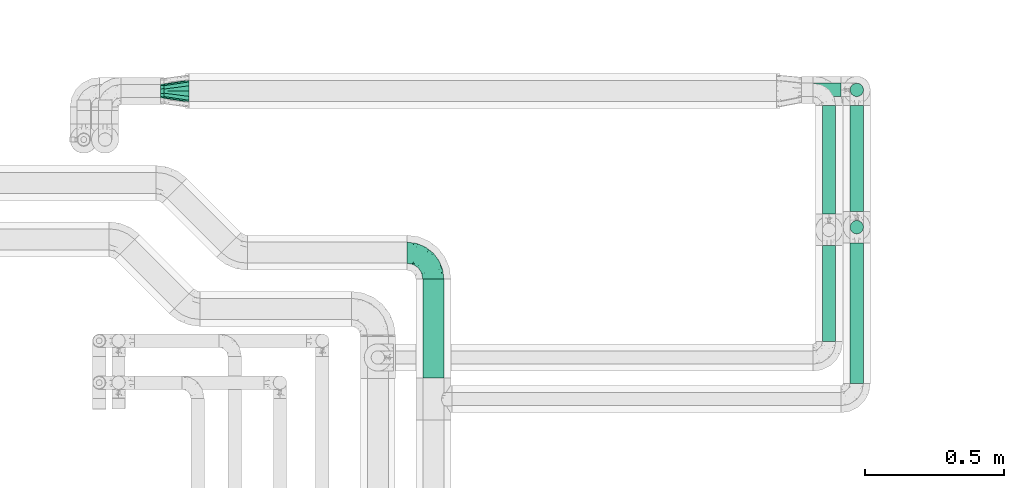
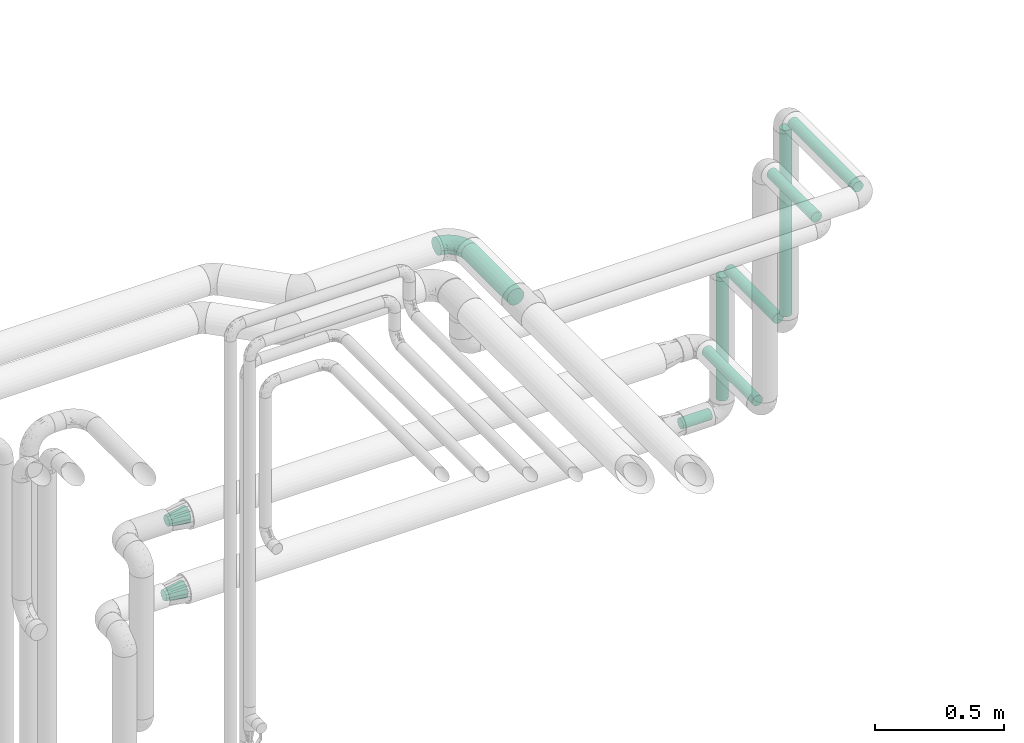
# One storey, part 684 of 824: 8 flow segments, 3 flow fittings.
"""IFC2X3 building model written with IfcOpenShell, lengths in millimetres."""

import ifcopenshell
import ifcopenshell.guid

model = None  # the IFC model being written
_history = None  # IfcOwnerHistory: only IFC2X3 demands one
_inside = {}  # id of a spatial element -> (the spatial element, [elements in it])
_under = {}  # id of a project, library or spatial element -> (it, [spatial elements below it])
_declared = {}  # id of a project -> (the project, [libraries it declares])
_typed = {}  # id of a type object -> (the type object, [elements of that type])
_made_of = {}  # id of a material, layer set ... -> (it, [elements and type objects made of it])


def new_model(schema):
    """Start an empty IFC model of exactly this schema.

    Asked for "IFC4X3", IfcOpenShell would pick the latest addendum, in which some entities
    have other attributes; the version numbers below select the first issue.
    IFC2X3 requires an IfcOwnerHistory on every rooted entity: one is made here for all.
    """
    global model, _history
    if schema == "IFC4X3":
        model = ifcopenshell.file(schema_version=(4, 3, 0, 0))
    else:
        model = ifcopenshell.file(schema=schema)
    _inside.clear()
    _under.clear()
    _declared.clear()
    _typed.clear()
    _made_of.clear()
    _history = None
    if model.schema == "IFC2X3":
        org = make("IfcOrganization", Name="unknown")
        user = make(
            "IfcPersonAndOrganization",
            ThePerson=make("IfcPerson", FamilyName="unknown"),
            TheOrganization=org,
        )
        app = make(
            "IfcApplication",
            ApplicationDeveloper=org,
            Version="unknown",
            ApplicationFullName="unknown",
            ApplicationIdentifier="unknown",
        )
        _history = make(
            "IfcOwnerHistory",
            OwningUser=user,
            OwningApplication=app,
            ChangeAction="ADDED",
            CreationDate=0,
        )
    return model


def make(cls, **values):
    """One entity of the class cls with the attributes given. An attribute that is None is left unset."""
    return model.create_entity(
        cls, **{name: value for name, value in values.items() if value is not None}
    )


def entity(cls, *values):
    """Any entity or typed value of the class cls, its attributes in the order of the schema. None: left unset."""
    e = model.create_entity(cls)
    for i, value in enumerate(values):
        if value is not None:
            e[i] = value
    return e


def rooted(cls, **values):
    """An entity with a GlobalId (a new one), such as an element, a storey or a relation."""
    return make(cls, GlobalId=ifcopenshell.guid.new(), OwnerHistory=_history, **values)


def si_unit(unit_type, name, prefix=None):
    """IfcSIUnit, for example si_unit("LENGTHUNIT", "METRE", prefix="MILLI")."""
    return make("IfcSIUnit", UnitType=unit_type, Prefix=prefix, Name=name)


def converted_unit(unit_type, name, factor, base, dimensions=None, offset=None):
    """IfcConversionBasedUnit, such as the inch: factor (a typed value) times the base unit."""
    return make(
        "IfcConversionBasedUnit"
        if offset is None
        else "IfcConversionBasedUnitWithOffset",
        ConversionOffset=offset,
        Dimensions=None
        if dimensions is None
        else entity("IfcDimensionalExponents", *dimensions),
        UnitType=unit_type,
        Name=name,
        ConversionFactor=make(
            "IfcMeasureWithUnit", ValueComponent=factor, UnitComponent=base
        ),
    )


def derived_unit(unit_type, elements):
    """IfcDerivedUnit: a product of units, each with its exponent."""
    return make(
        "IfcDerivedUnit",
        Elements=[
            make("IfcDerivedUnitElement", Unit=unit, Exponent=power)
            for unit, power in elements
        ],
        UnitType=unit_type,
    )


def assignment(units):
    """IfcUnitAssignment: the units of a project."""
    return None if units is None else make("IfcUnitAssignment", Units=units)


def point(xyz):
    """IfcCartesianPoint."""
    return None if xyz is None else make("IfcCartesianPoint", Coordinates=xyz)


def direction(xyz):
    """IfcDirection."""
    return None if xyz is None else make("IfcDirection", DirectionRatios=xyz)


def frame(location, z_axis=None, x_axis=None):
    """IfcAxis2Placement3D, a coordinate frame: its origin and axes. An axis left out is left unset."""
    return make(
        "IfcAxis2Placement3D",
        Location=point(location),
        Axis=direction(z_axis),
        RefDirection=direction(x_axis),
    )


def frame_2d(location, x_axis=None):
    """IfcAxis2Placement2D, a coordinate frame in the plane: its origin and x axis."""
    return make(
        "IfcAxis2Placement2D", Location=point(location), RefDirection=direction(x_axis)
    )


def origin():
    """The frame at (0, 0, 0) with its axes left unset."""
    return frame((0.0, 0.0, 0.0))


def origin_2d_with_axis():
    """The frame at (0, 0) in the plane with the x axis (1, 0) written out."""
    return frame_2d((0.0, 0.0), x_axis=(1.0, 0.0))


def place(relative_to, where):
    """IfcLocalPlacement: puts the frame where relative to a parent placement (None: the world)."""
    return make(
        "IfcLocalPlacement", PlacementRelTo=relative_to, RelativePlacement=where
    )


def context(
    kind, dimensions, precision=None, world=None, true_north=None, identifier=None
):
    """IfcGeometricRepresentationContext, for example the 3D "Model" context."""
    return make(
        "IfcGeometricRepresentationContext",
        ContextIdentifier=identifier,
        ContextType=kind,
        CoordinateSpaceDimension=dimensions,
        Precision=precision,
        WorldCoordinateSystem=world,
        TrueNorth=true_north,
    )


def subcontext(parent, identifier, kind, view, scale=None):
    """IfcGeometricRepresentationSubContext, for example "Body" below "Model"."""
    return make(
        "IfcGeometricRepresentationSubContext",
        ContextIdentifier=identifier,
        ContextType=kind,
        ParentContext=parent,
        TargetScale=scale,
        TargetView=view,
    )


def project(units=None, contexts=None):
    """IfcProject with its units and contexts."""
    return rooted(
        "IfcProject",
        Name="project",
        RepresentationContexts=contexts,
        UnitsInContext=assignment(units),
    )


def spatial(cls, under=None, at=None, **own):
    """A site, building, storey or space (cls), placed at a placement, below another one or the project."""
    s = rooted(cls, ObjectPlacement=at, **own)
    if under is not None:
        _under.setdefault(under.id(), (under, []))[1].append(s)
    return s


def profile(cls, at=None, kind="AREA", **sizes):
    """A parametric profile (cls). Its sizes go by their IFC names, for example OverallWidth=200.0."""
    return make(cls, ProfileType=kind, Position=at, **sizes)


def circle(**sizes):
    """IfcCircleProfileDef."""
    return profile("IfcCircleProfileDef", **sizes)


def extrude(swept, where, along, depth):
    """IfcExtrudedAreaSolid: the profile swept, set in the frame where, extruded along a direction by depth."""
    return make(
        "IfcExtrudedAreaSolid",
        SweptArea=swept,
        Position=where,
        ExtrudedDirection=direction(along),
        Depth=depth,
    )


def faces_of(points, faces, orient=None, outer=None):
    """IfcFace entities. A face is a list of loops; a loop is a list of indices into points, from 0.

    orient and outer hold one flag for each loop. By default every Orientation is true, the
    first loop of a face is its IfcFaceOuterBound and the others are IfcFaceBound.
    """
    made = []
    for i, loops in enumerate(faces):
        bounds = []
        for j, loop in enumerate(loops):
            is_outer = j == 0 if outer is None else outer[i][j]
            bounds.append(
                make(
                    "IfcFaceOuterBound" if is_outer else "IfcFaceBound",
                    Bound=make("IfcPolyLoop", Polygon=[points[k] for k in loop]),
                    Orientation=True if orient is None else orient[i][j],
                )
            )
        made.append(make("IfcFace", Bounds=bounds))
    return made


def faceted_brep(points, faces, orient=None, outer=None, voids=None):
    """IfcFacetedBrep: a solid bounded by flat faces; with voids (closed shells), ...WithVoids."""
    shared = [point(p) for p in points]
    hull = make("IfcClosedShell", CfsFaces=faces_of(shared, faces, orient, outer))
    if voids is None:
        return make("IfcFacetedBrep", Outer=hull)
    return make(
        "IfcFacetedBrepWithVoids",
        Outer=hull,
        Voids=[
            make(cls, CfsFaces=faces_of(shared, fs, o, b)) for cls, fs, o, b in voids
        ],
    )


def shape(context_of_items, identifier, shape_type, items):
    """IfcShapeRepresentation: the items that make up one representation, for example the "Body"."""
    return make(
        "IfcShapeRepresentation",
        ContextOfItems=context_of_items,
        RepresentationIdentifier=identifier,
        RepresentationType=shape_type,
        Items=items,
    )


def source(mapping_origin, context_of_items, identifier, shape_type, items):
    """IfcRepresentationMap: a shape defined once, which mapped items show again and again."""
    return make(
        "IfcRepresentationMap",
        MappingOrigin=mapping_origin,
        MappedRepresentation=shape(context_of_items, identifier, shape_type, items),
    )


def transform(
    local_origin,
    x_axis=None,
    y_axis=None,
    z_axis=None,
    scale=None,
    scale2=None,
    scale3=None,
    uniform=True,
):
    """IfcCartesianTransformationOperator3D, or its non-uniform kind. x_axis, y_axis, z_axis: its Axis1, 2, 3."""
    if uniform:
        return make(
            "IfcCartesianTransformationOperator3D",
            Axis1=direction(x_axis),
            Axis2=direction(y_axis),
            LocalOrigin=point(local_origin),
            Scale=scale,
            Axis3=direction(z_axis),
        )
    return make(
        "IfcCartesianTransformationOperator3DnonUniform",
        Axis1=direction(x_axis),
        Axis2=direction(y_axis),
        LocalOrigin=point(local_origin),
        Scale=scale,
        Axis3=direction(z_axis),
        Scale2=scale2,
        Scale3=scale3,
    )


def mapped(mapping_source, mapping_target):
    """IfcMappedItem: shows the shape of a source again, moved by a transform."""
    return make(
        "IfcMappedItem", MappingSource=mapping_source, MappingTarget=mapping_target
    )


def material(Name=None, Category=None):
    """IfcMaterial."""
    return make("IfcMaterial", Name=Name, Category=Category)


def made_of(thing, what):
    """Note that an element or type object is made of a material, layer set ...; save() writes the relation."""
    if what is not None:
        _made_of.setdefault(what.id(), (what, []))[1].append(thing)
    return thing


def type_object(cls, material=None, **own):
    """A type object (cls), such as IfcWallType, which elements share."""
    return made_of(rooted(cls, **own), material)


def type_shapes(of_type, sources):
    """Give a type object the sources (RepresentationMaps) that its elements show as mapped items."""
    of_type.RepresentationMaps = sources


def element(
    cls,
    number,
    at=None,
    inside=None,
    cuts=None,
    type_object=None,
    material=None,
    context=None,
    identifier="Body",
    shape_type=None,
    held_by="IfcProductDefinitionShape",
    body=None,
    shapes=None,
    **own,
):
    """One element of the class cls, such as IfcWall. Its Tag is "e" and its number.

    at: its placement. inside: the storey or other place that contains it. cuts: it is an
    opening in that element (IfcRelVoidsElement). A single representation is given by context,
    identifier, shape_type and body (its items); several are given by shapes. held_by: the class
    of the entity that holds the representations. save() writes the other relations.
    """
    e = rooted(cls, Tag="e%d" % number, ObjectPlacement=at, **own)
    if body is not None:
        shapes = [shape(context, identifier, shape_type, body)]
    if shapes is not None:
        e.Representation = make(held_by, Representations=shapes)
    if inside is not None:
        _inside.setdefault(inside.id(), (inside, []))[1].append(e)
    if cuts is not None:
        rooted(
            "IfcRelVoidsElement", RelatingBuildingElement=cuts, RelatedOpeningElement=e
        )
    if type_object is not None:
        _typed.setdefault(type_object.id(), (type_object, []))[1].append(e)
    return made_of(e, material)


def aggregate(whole, parts):
    """IfcRelAggregates: a whole, such as a stair, and the parts it consists of."""
    return rooted("IfcRelAggregates", RelatingObject=whole, RelatedObjects=parts)


def save(model, path):
    """Write the relations noted so far, then the file.

    IfcRelAggregates (storeys below a building ...), IfcRelContainedInSpatialStructure (elements
    in a storey), IfcRelDefinesByType, IfcRelAssociatesMaterial and IfcRelDeclares: one each for
    every whole, place, type object, material and project.
    """
    for whole, parts in _under.values():
        aggregate(whole, parts)
    for where, things in _inside.values():
        rooted(
            "IfcRelContainedInSpatialStructure",
            RelatedElements=things,
            RelatingStructure=where,
        )
    for kind, things in _typed.values():
        rooted("IfcRelDefinesByType", RelatedObjects=things, RelatingType=kind)
    for what, things in _made_of.values():
        rooted("IfcRelAssociatesMaterial", RelatedObjects=things, RelatingMaterial=what)
    for by, libraries in _declared.values():
        rooted("IfcRelDeclares", RelatingContext=by, RelatedDefinitions=libraries)
    model.write(path)


model = new_model("IFC2X3")

# Units and contexts
model_context = context("Model", 3, precision=0.01, world=origin(), true_north=direction((6.12303176911189e-17, 1.0)))
body_context = subcontext(model_context, "Body", "Model", "MODEL_VIEW")
ifc_project = project(units=[si_unit("LENGTHUNIT", "METRE", prefix="MILLI"), si_unit("AREAUNIT", "SQUARE_METRE"), si_unit("VOLUMEUNIT", "CUBIC_METRE"), converted_unit("PLANEANGLEUNIT", "DEGREE", entity("IfcRatioMeasure", 0.0174532925199433), si_unit("PLANEANGLEUNIT", "RADIAN"), dimensions=[0, 0, 0, 0, 0, 0, 0]), si_unit("MASSUNIT", "GRAM", prefix="KILO"), derived_unit("MASSDENSITYUNIT", [(si_unit("MASSUNIT", "GRAM", prefix="KILO"), 1), (si_unit("LENGTHUNIT", "METRE"), -3)]), derived_unit("MOMENTOFINERTIAUNIT", [(si_unit("LENGTHUNIT", "METRE"), 4)]), si_unit("TIMEUNIT", "SECOND"), si_unit("FREQUENCYUNIT", "HERTZ"), si_unit("THERMODYNAMICTEMPERATUREUNIT", "DEGREE_CELSIUS"), derived_unit("THERMALTRANSMITTANCEUNIT", [(si_unit("MASSUNIT", "GRAM", prefix="KILO"), 1), (si_unit("THERMODYNAMICTEMPERATUREUNIT", "KELVIN"), -1), (si_unit("TIMEUNIT", "SECOND"), -3)]), derived_unit("VOLUMETRICFLOWRATEUNIT", [(si_unit("LENGTHUNIT", "METRE"), 3), (si_unit("TIMEUNIT", "SECOND"), -1)]), derived_unit("MASSFLOWRATEUNIT", [(si_unit("MASSUNIT", "GRAM", prefix="KILO"), 1), (si_unit("TIMEUNIT", "SECOND"), -1)]), derived_unit("ROTATIONALFREQUENCYUNIT", [(si_unit("TIMEUNIT", "SECOND"), -1)]), si_unit("ELECTRICCURRENTUNIT", "AMPERE"), si_unit("ELECTRICVOLTAGEUNIT", "VOLT"), si_unit("POWERUNIT", "WATT"), si_unit("FORCEUNIT", "NEWTON", prefix="KILO"), si_unit("ILLUMINANCEUNIT", "LUX"), si_unit("LUMINOUSFLUXUNIT", "LUMEN"), si_unit("LUMINOUSINTENSITYUNIT", "CANDELA"), derived_unit("USERDEFINED", [(si_unit("MASSUNIT", "GRAM", prefix="KILO"), -1), (si_unit("LENGTHUNIT", "METRE"), -2), (si_unit("TIMEUNIT", "SECOND"), 3), (si_unit("LUMINOUSFLUXUNIT", "LUMEN"), 1)]), derived_unit("LINEARVELOCITYUNIT", [(si_unit("LENGTHUNIT", "METRE"), 1), (si_unit("TIMEUNIT", "SECOND"), -1)]), si_unit("PRESSUREUNIT", "PASCAL"), derived_unit("USERDEFINED", [(si_unit("LENGTHUNIT", "METRE"), -2), (si_unit("MASSUNIT", "GRAM", prefix="KILO"), 1), (si_unit("TIMEUNIT", "SECOND"), -2)]), derived_unit("LINEARFORCEUNIT", [(si_unit("MASSUNIT", "GRAM", prefix="KILO"), 1), (si_unit("LENGTHUNIT", "METRE"), 1), (si_unit("TIMEUNIT", "SECOND"), -2), (si_unit("LENGTHUNIT", "METRE"), -1)]), derived_unit("PLANARFORCEUNIT", [(si_unit("MASSUNIT", "GRAM", prefix="KILO"), 1), (si_unit("LENGTHUNIT", "METRE"), 1), (si_unit("TIMEUNIT", "SECOND"), -2), (si_unit("LENGTHUNIT", "METRE"), -2)])], contexts=[model_context])

# Site, building, storey
site_placement = place(None, origin())
site = spatial("IfcSite", under=ifc_project, at=site_placement, CompositionType="ELEMENT")
building_placement = place(site_placement, origin())
building = spatial("IfcBuilding", under=site, at=building_placement, CompositionType="ELEMENT")
storey_placement = place(building_placement, frame((0.0, 0.0, 28200.0)))
storey = spatial("IfcBuildingStorey", under=building, at=storey_placement, CompositionType="ELEMENT", Elevation=28200.0)

# Flow segments
pipe_segment_type = type_object("IfcPipeSegmentType", PredefinedType="NOTDEFINED")
flow_segment_1_placement = place(storey_placement, frame((48805.69, 18106.53, 2960.65)))
element("IfcFlowSegment", 1, at=flow_segment_1_placement, inside=storey, type_object=pipe_segment_type, context=body_context, shape_type="SweptSolid", body=[
    extrude(circle(Radius=37.75, at=origin_2d_with_axis()), frame((39.35, 0.0, 39.35), z_axis=(0.0, 1.0, 0.0), x_axis=(-1.0, 0.0, 0.0)), (0.0, 0.0, 1.0), 356.978263748389),
])
flow_segment_2_placement = place(storey_placement, frame((50346.44, 18087.53, 2974.4)))
element("IfcFlowSegment", 2, at=flow_segment_2_placement, inside=storey, type_object=pipe_segment_type, context=body_context, shape_type="SweptSolid", body=[
    extrude(circle(Radius=24.0, at=origin_2d_with_axis()), frame((25.6, 0.0, 25.6), z_axis=(0.0, 1.0, 0.0), x_axis=(1.0, 0.0, 0.0)), (0.0, 0.0, 1.0), 506.000000000015),
])
flow_segment_3_placement = place(storey_placement, frame((50346.44, 18624.93, 2057.0)))
element("IfcFlowSegment", 3, at=flow_segment_3_placement, inside=storey, type_object=pipe_segment_type, context=body_context, shape_type="SweptSolid", body=[
    extrude(circle(Radius=24.0, at=origin_2d_with_axis()), frame((25.6, 25.6, 0.0)), (0.0, 0.0, 1.0), 886.000000000011),
])
flow_segment_4_placement = place(storey_placement, frame((50246.44, 18237.53, 2774.4)))
element("IfcFlowSegment", 4, at=flow_segment_4_placement, inside=storey, type_object=pipe_segment_type, context=body_context, shape_type="SweptSolid", body=[
    extrude(circle(Radius=24.0, at=origin_2d_with_axis()), frame((25.6, 0.0, 25.6), z_axis=(0.0, 1.0, 0.0), x_axis=(1.0, 0.0, 0.0)), (0.0, 0.0, 1.0), 345.999999999956),
])
flow_segment_5_placement = place(storey_placement, frame((50346.44, 18707.53, 1974.4)))
element("IfcFlowSegment", 5, at=flow_segment_5_placement, inside=storey, type_object=pipe_segment_type, context=body_context, shape_type="SweptSolid", body=[
    extrude(circle(Radius=24.0, at=origin_2d_with_axis()), frame((25.6, 0.0, 25.6), z_axis=(0.0, 1.0, 0.0), x_axis=(1.0, 0.0, 0.0)), (0.0, 0.0, 1.0), 381.000000000009),
])
flow_segment_6_placement = place(storey_placement, frame((50346.44, 19119.93, 1357.0)))
element("IfcFlowSegment", 6, at=flow_segment_6_placement, inside=storey, type_object=pipe_segment_type, context=body_context, shape_type="SweptSolid", body=[
    extrude(circle(Radius=24.0, at=origin_2d_with_axis()), frame((25.6, 25.6, 0.0)), (0.0, 0.0, 1.0), 586.00000000001),
])
flow_segment_7_placement = place(storey_placement, frame((50185.03, 19119.93, 1274.4)))
element("IfcFlowSegment", 7, at=flow_segment_7_placement, inside=storey, type_object=pipe_segment_type, context=body_context, shape_type="SweptSolid", body=[
    extrude(circle(Radius=24.0, at=origin_2d_with_axis()), frame((0.0, 25.6, 25.6), z_axis=(1.0, 0.0, 0.0), x_axis=(0.0, 1.0, 0.0)), (0.0, 0.0, 1.0), 130.000000000005),
])
flow_segment_8_placement = place(storey_placement, frame((50246.44, 18697.53, 1624.4)))
element("IfcFlowSegment", 8, at=flow_segment_8_placement, inside=storey, type_object=pipe_segment_type, context=body_context, shape_type="SweptSolid", body=[
    extrude(circle(Radius=24.0, at=origin_2d_with_axis()), frame((25.6, 0.0, 25.6), z_axis=(0.0, 1.0, 0.0), x_axis=(1.0, 0.0, 0.0)), (0.0, 0.0, 1.0), 390.99999997821),
])

# Flow fittings
ifc_material = material()
pipe_fitting_type_1 = type_object("IfcPipeFittingType", PredefinedType="NOTDEFINED", material=ifc_material)
shared_shape_1 = source(origin(), body_context, "Body", "Brep", [
    faceted_brep([(-95.0, 19.02, -32.95), (-95.0, 9.85, -36.75), (-95.0, 0.0, -38.05), (-95.0, -9.85, -36.75), (-95.0, -19.03, -32.95), (-95.0, -26.91, -26.91), (-95.0, -32.95, -19.03), (-95.0, -36.75, -9.85), (-95.0, -38.05, 0.0), (-95.0, -36.75, 9.85), (-95.0, -32.95, 19.02), (-95.0, -26.91, 26.91), (-95.0, -19.03, 32.95), (-95.0, -9.85, 36.75), (-95.0, 0.0, 38.05), (-95.0, 9.85, 36.75), (-95.0, 19.02, 32.95), (-95.0, 26.91, 26.91), (-95.0, 32.95, 19.02), (-95.0, 36.75, 9.85), (-95.0, 38.05, 0.0), (-95.0, 36.75, -9.85), (-95.0, 32.95, -19.03), (-95.0, 26.91, -26.91), (0.0, 95.0, -38.05), (-9.85, 95.0, -36.75), (-19.02, 95.0, -32.95), (-26.91, 95.0, -26.91), (-32.95, 95.0, -19.03), (-36.75, 95.0, -9.85), (-38.05, 95.0, 0.0), (-36.75, 95.0, 9.85), (-32.95, 95.0, 19.02), (-26.91, 95.0, 26.91), (-19.02, 95.0, 32.95), (-9.85, 95.0, 36.75), (0.0, 95.0, 38.05), (9.85, 95.0, 36.75), (19.03, 95.0, 32.95), (26.91, 95.0, 26.91), (32.95, 95.0, 19.02), (36.75, 95.0, 9.85), (38.05, 95.0, 0.0), (36.75, 95.0, -9.85), (32.95, 95.0, -19.03), (26.91, 95.0, -26.91), (19.03, 95.0, -32.95), (9.85, 95.0, -36.75), (-7.99, -4.96, 6.3), (-0.92, 0.92, 0.0), (4.62, 8.1, 8.01), (-76.19, -35.57, 0.0), (-64.32, -32.32, 12.43), (20.51, 62.45, 28.68), (-60.56, -33.52, 0.0), (-70.4, -13.47, 34.42), (-39.61, -5.88, 32.32), (-49.6, 2.07, 37.1), (-70.34, -28.81, 21.71), (14.64, 40.81, 26.5), (5.88, 39.61, 32.32), (3.59, 20.77, 25.31), (-40.45, 68.06, 16.75), (-62.45, -20.51, 28.68), (-44.52, -26.87, 0.0), (-28.47, -20.22, 0.0), (-26.43, -17.83, 8.75), (-76.1, 39.63, 10.76), (-72.74, 37.58, 18.19), (-60.35, 46.18, 14.61), (-13.4, 13.4, 32.12), (-20.77, -3.59, 25.31), (-14.66, 81.47, 35.56), (-6.22, 71.26, 37.92), (-57.5, 42.48, 22.79), (-15.0, 34.74, 37.7), (-27.1, 12.08, 36.05), (-9.2, 28.81, 35.63), (-79.98, 23.7, 30.95), (-73.68, -4.3, 37.48), (-30.74, 21.67, 37.97), (-62.36, 47.59, 6.79), (-72.71, 32.83, 24.69), (-67.42, 7.02, 37.95), (-32.13, 75.27, 24.51), (-43.46, 51.47, 26.26), (-24.98, 73.15, 31.29), (20.59, 41.28, 19.85), (7.79, 16.09, 15.86), (-73.21, 42.39, 0.0), (-54.73, 54.73, 0.0), (-73.44, 15.79, 35.79), (-5.94, 4.32, 20.43), (28.81, 70.34, 21.71), (32.32, 64.32, 12.43), (-53.59, 26.2, 35.09), (-52.02, 19.31, 37.21), (21.38, 33.53, 10.34), (26.87, 44.52, 0.0), (-48.28, 12.14, 38.05), (4.3, 73.68, 37.48), (-44.08, -25.52, 12.79), (-41.28, -20.59, 19.85), (35.57, 76.19, 0.0), (-47.26, 54.3, 20.18), (-47.4, 61.99, 8.58), (-42.39, 73.21, 0.0), (-39.67, 78.86, 7.21), (-45.69, 36.84, 33.11), (-32.83, 50.13, 33.35), (13.47, 70.4, 34.42), (-18.25, 63.73, 36.07), (-40.63, -13.75, 27.22), (-16.63, 46.37, 37.95), (-53.47, 38.79, 28.59), (-26.07, 48.54, 36.15), (-34.51, 34.51, 36.86), (-2.07, 49.6, 37.1), (-22.79, -10.49, 19.23), (-61.73, 28.67, 31.87), (9.65, 14.7, 0.0), (20.22, 28.47, 0.0), (33.52, 60.56, 0.0), (-11.42, -5.44, 13.25), (-14.7, -9.65, 0.0), (-81.47, 14.66, -35.56), (-62.45, -20.51, -28.68), (-71.26, 6.22, -37.92), (-75.27, 32.13, -24.51), (-73.15, 24.98, -31.29), (13.47, 70.4, -34.42), (5.88, 39.61, -32.32), (-2.07, 49.6, -37.1), (-78.86, 39.67, -7.21), (-70.4, -13.47, -34.42), (-39.61, -5.88, -32.32), (-61.99, 47.4, -8.58), (32.32, 64.32, -12.43), (28.81, 70.34, -21.71), (-63.73, 18.25, -36.07), (-50.13, 32.83, -33.35), (4.3, 73.68, -37.48), (-7.02, 67.42, -37.95), (-39.63, 76.1, -10.76), (-46.18, 60.35, -14.61), (-47.59, 62.36, -6.79), (-64.32, -32.32, -12.43), (-26.2, 53.59, -35.09), (-15.79, 73.44, -35.79), (-19.31, 52.02, -37.21), (-37.58, 72.74, -18.19), (-70.34, -28.81, -21.71), (-42.48, 57.5, -22.79), (-38.79, 53.47, -28.59), (-51.47, 43.46, -26.26), (-32.83, 72.71, -24.69), (-46.37, 16.63, -37.95), (-73.68, -4.3, -37.48), (-41.28, -20.59, -19.85), (-44.08, -25.52, -12.79), (13.75, 40.63, -27.22), (20.51, 62.45, -28.68), (-68.06, 40.45, -16.75), (-54.3, 47.26, -20.18), (-12.14, 48.28, -38.05), (-21.67, 30.74, -37.97), (-36.84, 45.69, -33.11), (-11.42, -5.44, -13.25), (7.79, 16.09, -15.86), (4.62, 8.1, -8.01), (-23.7, 79.98, -30.95), (-26.43, -17.83, -8.75), (-7.99, -4.96, -6.3), (-40.81, -14.64, -26.5), (-20.77, -3.59, -25.31), (-34.74, 15.0, -37.7), (-12.08, 27.1, -36.05), (-28.81, 9.2, -35.63), (-22.79, -10.49, -19.23), (21.38, 33.53, -10.34), (20.59, 41.28, -19.85), (-48.54, 26.07, -36.15), (-49.6, 2.07, -37.1), (-13.4, 13.4, -32.12), (3.59, 20.77, -25.31), (-28.67, 61.73, -31.87), (-34.51, 34.51, -36.86), (-5.94, 4.32, -20.43)], [[[0, 1, 2, 3, 4, 5, 6, 7, 8, 9, 10, 11, 12, 13, 14, 15, 16, 17, 18, 19, 20, 21, 22, 23]], [[24, 25, 26, 27, 28, 29, 30, 31, 32, 33, 34, 35, 36, 37, 38, 39, 40, 41, 42, 43, 44, 45, 46, 47]], [[48, 49, 50]], [[51, 52, 9]], [[53, 39, 38]], [[9, 52, 10]], [[54, 52, 51]], [[55, 56, 57]], [[11, 10, 58]], [[59, 60, 61]], [[32, 31, 62]], [[63, 12, 11]], [[63, 55, 12]], [[64, 65, 66]], [[67, 68, 69]], [[70, 56, 71]], [[35, 72, 73]], [[69, 68, 74]], [[75, 76, 77]], [[16, 78, 17]], [[13, 79, 14]], [[76, 75, 80]], [[67, 69, 81]], [[18, 17, 82]], [[14, 79, 83]], [[20, 19, 67]], [[84, 85, 86]], [[87, 61, 88]], [[89, 81, 90]], [[18, 82, 68]], [[15, 91, 16]], [[14, 83, 15]], [[71, 92, 61]], [[17, 78, 82]], [[93, 87, 94]], [[95, 91, 96]], [[97, 98, 94]], [[86, 72, 34]], [[96, 99, 80]], [[37, 36, 100]], [[40, 39, 93]], [[40, 94, 41]], [[64, 66, 101]], [[93, 94, 40]], [[58, 102, 63]], [[94, 103, 41]], [[94, 87, 97]], [[104, 69, 74]], [[34, 33, 86]], [[105, 69, 104]], [[52, 58, 10]], [[106, 107, 30]], [[108, 109, 85]], [[105, 106, 90]], [[53, 110, 60]], [[86, 111, 72]], [[86, 109, 111]], [[33, 84, 86]], [[12, 55, 13]], [[112, 56, 63]], [[110, 38, 37]], [[34, 72, 35]], [[36, 35, 73]], [[111, 113, 73]], [[105, 107, 106]], [[110, 53, 38]], [[74, 114, 85]], [[91, 15, 83]], [[105, 90, 81]], [[107, 62, 31]], [[33, 32, 84]], [[115, 109, 116]], [[111, 115, 113]], [[100, 73, 117]], [[56, 55, 63]], [[79, 55, 57]], [[102, 118, 112]], [[56, 70, 76]], [[100, 110, 37]], [[117, 77, 60]], [[117, 60, 110]], [[60, 70, 61]], [[58, 52, 101]], [[63, 11, 58]], [[39, 53, 93]], [[87, 93, 53]], [[96, 91, 83]], [[78, 91, 119]], [[32, 62, 84]], [[84, 62, 104]], [[86, 85, 109]], [[85, 114, 108]], [[80, 113, 116]], [[117, 73, 113]], [[80, 116, 96]], [[80, 57, 76]], [[71, 112, 118]], [[61, 87, 59]], [[62, 107, 105]], [[97, 120, 121]], [[70, 71, 61]], [[71, 118, 92]], [[73, 100, 36]], [[110, 100, 117]], [[55, 79, 13]], [[83, 79, 57]], [[96, 83, 99]], [[116, 108, 95]], [[50, 97, 88]], [[97, 87, 88]], [[50, 49, 120]], [[122, 94, 98]], [[89, 20, 67]], [[105, 81, 69]], [[89, 67, 81]], [[68, 19, 18]], [[68, 67, 19]], [[74, 68, 82]], [[114, 82, 119]], [[74, 85, 104]], [[82, 114, 74]], [[114, 119, 108]], [[95, 108, 119]], [[116, 109, 108]], [[123, 48, 50]], [[97, 50, 120]], [[123, 50, 88]], [[91, 95, 119]], [[116, 95, 96]], [[84, 104, 85]], [[104, 62, 105]], [[83, 57, 99]], [[57, 80, 99]], [[66, 48, 123]], [[66, 124, 48]], [[118, 66, 123]], [[124, 66, 65]], [[66, 118, 101]], [[54, 64, 52]], [[124, 49, 48]], [[30, 107, 31]], [[91, 78, 16]], [[82, 78, 119]], [[56, 76, 57]], [[77, 76, 70]], [[60, 77, 70]], [[77, 117, 75]], [[117, 113, 75]], [[113, 80, 75]], [[9, 8, 51]], [[103, 94, 122]], [[103, 42, 41]], [[73, 72, 111]], [[113, 115, 116]], [[111, 109, 115]], [[102, 112, 63]], [[71, 56, 112]], [[118, 102, 101]], [[92, 123, 88]], [[123, 92, 118]], [[61, 92, 88]], [[87, 53, 59]], [[60, 59, 53]], [[97, 121, 98]], [[58, 101, 102]], [[64, 101, 52]], [[125, 1, 0]], [[126, 5, 4]], [[2, 1, 127]], [[1, 125, 127]], [[128, 129, 23]], [[130, 131, 132]], [[89, 133, 20]], [[126, 134, 135]], [[136, 89, 90]], [[137, 138, 44]], [[139, 129, 140]], [[24, 141, 142]], [[143, 144, 145]], [[125, 129, 139]], [[6, 146, 7]], [[147, 148, 149]], [[146, 51, 7]], [[143, 150, 144]], [[146, 6, 151]], [[152, 153, 154]], [[126, 4, 134]], [[0, 23, 129]], [[28, 155, 150]], [[43, 42, 103]], [[54, 146, 64]], [[139, 156, 127]], [[157, 3, 2]], [[151, 158, 159]], [[160, 131, 161]], [[22, 21, 162]], [[136, 144, 163]], [[149, 164, 165]], [[24, 142, 25]], [[166, 140, 154]], [[154, 129, 128]], [[143, 30, 29]], [[167, 168, 169]], [[155, 28, 27]], [[26, 170, 27]], [[171, 167, 172]], [[26, 25, 148]], [[27, 170, 155]], [[173, 135, 174]], [[144, 150, 152]], [[175, 176, 177]], [[24, 47, 141]], [[45, 161, 46]], [[148, 25, 142]], [[176, 175, 165]], [[64, 159, 171]], [[138, 45, 44]], [[130, 46, 161]], [[137, 44, 43]], [[178, 159, 158]], [[137, 103, 122]], [[163, 144, 152]], [[136, 133, 89]], [[103, 137, 43]], [[6, 5, 151]], [[178, 158, 173]], [[134, 4, 3]], [[178, 173, 174]], [[137, 98, 179]], [[145, 90, 106]], [[138, 180, 161]], [[46, 130, 47]], [[136, 90, 145]], [[133, 162, 21]], [[23, 22, 128]], [[139, 140, 181]], [[139, 181, 156]], [[157, 127, 182]], [[157, 134, 3]], [[182, 177, 135]], [[182, 135, 134]], [[135, 183, 174]], [[131, 130, 161]], [[141, 130, 132]], [[160, 180, 184]], [[131, 183, 176]], [[5, 126, 151]], [[158, 151, 126]], [[180, 138, 137]], [[161, 45, 138]], [[149, 148, 142]], [[170, 148, 185]], [[22, 162, 128]], [[128, 162, 163]], [[129, 154, 140]], [[154, 153, 166]], [[165, 156, 186]], [[182, 127, 156]], [[165, 186, 149]], [[165, 132, 176]], [[131, 184, 183]], [[187, 167, 178]], [[184, 168, 187]], [[167, 169, 172]], [[184, 180, 168]], [[174, 183, 184]], [[127, 157, 2]], [[134, 157, 182]], [[130, 141, 47]], [[142, 141, 132]], [[149, 142, 164]], [[186, 166, 147]], [[180, 179, 168]], [[169, 179, 120]], [[137, 179, 180]], [[179, 121, 120]], [[106, 30, 143]], [[136, 145, 144]], [[106, 143, 145]], [[150, 29, 28]], [[150, 143, 29]], [[152, 150, 155]], [[153, 155, 185]], [[152, 154, 163]], [[155, 153, 152]], [[153, 185, 166]], [[147, 166, 185]], [[186, 140, 166]], [[169, 120, 49]], [[169, 49, 172]], [[179, 169, 168]], [[148, 147, 185]], [[186, 147, 149]], [[128, 163, 154]], [[163, 162, 136]], [[142, 132, 164]], [[132, 165, 164]], [[171, 124, 65]], [[124, 171, 172]], [[64, 146, 159]], [[171, 159, 178]], [[171, 65, 64]], [[172, 49, 124]], [[162, 133, 136]], [[20, 133, 21]], [[148, 170, 26]], [[155, 170, 185]], [[131, 176, 132]], [[177, 176, 183]], [[135, 177, 183]], [[177, 182, 175]], [[182, 156, 175]], [[156, 165, 175]], [[51, 146, 54]], [[51, 8, 7]], [[129, 125, 0]], [[127, 125, 139]], [[140, 186, 181]], [[156, 181, 186]], [[158, 126, 173]], [[135, 173, 126]], [[187, 178, 174]], [[171, 178, 167]], [[184, 187, 174]], [[167, 187, 168]], [[180, 160, 161]], [[184, 131, 160]], [[98, 137, 122]], [[98, 121, 179]], [[151, 159, 146]]]),
])
type_shapes(pipe_fitting_type_1, [shared_shape_1])
flow_fitting_1_placement = place(storey_placement, frame((48845.03, 18558.51, 3000.0), z_axis=(0.0, 0.0, 1.0), x_axis=(0.0, 1.0, 0.0)))
element("IfcFlowFitting", 9, at=flow_fitting_1_placement, inside=storey, type_object=pipe_fitting_type_1, material=ifc_material, context=body_context, shape_type="MappedRepresentation", body=[
    mapped(shared_shape_1, transform((0.0, 0.0, 0.0), scale=1.0)),
])
pipe_fitting_type_2 = type_object("IfcPipeFittingType", PredefinedType="NOTDEFINED", material=ifc_material)
shared_shape_2 = source(origin(), body_context, "Body", "Brep", [
    faceted_brep([(89.0, 24.15, 0.0), (89.0, 21.84, 7.1), (89.0, 19.54, 14.2), (89.0, 13.5, 18.58), (89.0, 7.46, 22.97), (89.0, 0.0, 22.97), (89.0, -7.46, 22.97), (89.0, -13.5, 18.58), (89.0, -19.54, 14.2), (89.0, -21.84, 7.1), (89.0, -24.15, 0.0), (89.0, -21.84, -7.1), (89.0, -19.54, -14.2), (89.0, -13.5, -18.58), (89.0, -7.46, -22.97), (89.0, 0.0, -22.97), (89.0, 7.46, -22.97), (89.0, 13.5, -18.58), (89.0, 19.54, -14.2), (89.0, 21.84, -7.1), (0.0, 25.99, 25.99), (0.0, 32.95, 19.02), (0.0, 36.21, 6.85), (0.0, 38.05, 0.0), (0.0, 36.21, -6.85), (0.0, 32.95, -19.03), (0.0, 25.99, -25.99), (0.0, 19.03, -32.95), (0.0, 9.51, -35.5), (0.0, 0.0, -38.05), (0.0, -9.51, -35.5), (0.0, -19.03, -32.95), (0.0, -25.99, -25.99), (0.0, -32.95, -19.02), (0.0, -36.21, -6.85), (0.0, -38.05, 0.0), (0.0, -36.21, 6.85), (0.0, -32.95, 19.02), (0.0, -25.99, 25.99), (0.0, -19.02, 32.95), (0.0, -9.51, 35.5), (0.0, 0.0, 38.05), (0.0, 9.51, 35.5), (0.0, 19.02, 32.95)], [[[0, 1, 2, 3, 4, 5, 6, 7, 8, 9, 10, 11, 12, 13, 14, 15, 16, 17, 18, 19]], [[20, 21, 22, 23, 24, 25, 26, 27, 28, 29, 30, 31, 32, 33, 34, 35, 36, 37, 38, 39, 40, 41, 42, 43]], [[26, 17, 27]], [[25, 18, 26]], [[17, 26, 18]], [[25, 19, 18]], [[24, 0, 19]], [[31, 14, 13]], [[17, 16, 27]], [[28, 27, 16]], [[14, 30, 15]], [[16, 15, 28]], [[12, 32, 13]], [[10, 35, 34]], [[30, 29, 15]], [[10, 34, 11]], [[25, 24, 19]], [[14, 31, 30]], [[0, 24, 23]], [[11, 33, 12]], [[12, 33, 32]], [[33, 11, 34]], [[31, 13, 32]], [[28, 15, 29]], [[38, 7, 39]], [[37, 8, 38]], [[7, 38, 8]], [[37, 9, 8]], [[36, 10, 9]], [[43, 4, 3]], [[7, 6, 39]], [[40, 39, 6]], [[4, 42, 5]], [[6, 5, 40]], [[2, 20, 3]], [[0, 23, 22]], [[42, 41, 5]], [[0, 22, 1]], [[37, 36, 9]], [[4, 43, 42]], [[10, 36, 35]], [[1, 21, 2]], [[2, 21, 20]], [[21, 1, 22]], [[43, 3, 20]], [[40, 5, 41]]]),
])
type_shapes(pipe_fitting_type_2, [shared_shape_2])
flow_fitting_2_placement = place(storey_placement, frame((47950.3, 19141.22, 1300.0), z_axis=(0.0, 0.0, 1.0), x_axis=(-1.0, 0.0, 0.0)))
element("IfcFlowFitting", 10, at=flow_fitting_2_placement, inside=storey, type_object=pipe_fitting_type_2, material=ifc_material, context=body_context, shape_type="MappedRepresentation", body=[
    mapped(shared_shape_2, transform((0.0, 0.0, 0.0), scale=1.0)),
])
pipe_fitting_type_3 = type_object("IfcPipeFittingType", PredefinedType="NOTDEFINED", material=ifc_material)
shared_shape_3 = source(origin(), body_context, "Body", "Brep", [
    faceted_brep([(89.0, -38.05, 0.0), (89.0, -36.21, -6.85), (89.0, -32.95, -19.02), (89.0, -25.99, -25.99), (89.0, -19.03, -32.95), (89.0, -9.51, -35.5), (89.0, 0.0, -38.05), (89.0, 9.51, -35.5), (89.0, 19.02, -32.95), (89.0, 25.99, -25.99), (89.0, 32.95, -19.02), (89.0, 36.21, -6.85), (89.0, 38.05, 0.0), (89.0, 36.21, 6.85), (89.0, 32.95, 19.03), (89.0, 25.99, 25.99), (89.0, 19.02, 32.95), (89.0, 9.51, 35.5), (89.0, 0.0, 38.05), (89.0, -9.51, 35.5), (89.0, -19.03, 32.95), (89.0, -25.99, 25.99), (89.0, -32.95, 19.03), (89.0, -36.21, 6.85), (0.0, 24.15, 0.0), (0.0, 21.84, -7.1), (0.0, 19.54, -14.2), (0.0, 13.5, -18.58), (0.0, 7.46, -22.97), (0.0, 0.0, -22.97), (0.0, -7.46, -22.97), (0.0, -13.5, -18.58), (0.0, -19.54, -14.2), (0.0, -21.84, -7.1), (0.0, -24.15, 0.0), (0.0, -21.84, 7.1), (0.0, -19.54, 14.2), (0.0, -13.5, 18.58), (0.0, -7.46, 22.97), (0.0, 0.0, 22.97), (0.0, 7.46, 22.97), (0.0, 13.5, 18.58), (0.0, 19.54, 14.2), (0.0, 21.84, 7.1)], [[[0, 1, 2, 3, 4, 5, 6, 7, 8, 9, 10, 11, 12, 13, 14, 15, 16, 17, 18, 19, 20, 21, 22, 23]], [[24, 25, 26, 27, 28, 29, 30, 31, 32, 33, 34, 35, 36, 37, 38, 39, 40, 41, 42, 43]], [[2, 33, 32]], [[28, 7, 29]], [[29, 5, 30]], [[24, 12, 11]], [[3, 32, 31]], [[34, 1, 0]], [[1, 34, 33]], [[8, 28, 27]], [[2, 1, 33]], [[31, 4, 3]], [[2, 32, 3]], [[11, 25, 24]], [[26, 10, 9]], [[10, 25, 11]], [[28, 8, 7]], [[27, 26, 9]], [[26, 25, 10]], [[31, 30, 4]], [[8, 27, 9]], [[29, 7, 6]], [[5, 29, 6]], [[5, 4, 30]], [[14, 43, 42]], [[38, 19, 39]], [[39, 17, 40]], [[34, 0, 23]], [[15, 42, 41]], [[24, 13, 12]], [[13, 24, 43]], [[20, 38, 37]], [[14, 13, 43]], [[41, 16, 15]], [[14, 42, 15]], [[23, 35, 34]], [[36, 22, 21]], [[22, 35, 23]], [[38, 20, 19]], [[37, 36, 21]], [[36, 35, 22]], [[41, 40, 16]], [[20, 37, 21]], [[39, 19, 18]], [[17, 39, 18]], [[17, 16, 40]]]),
])
type_shapes(pipe_fitting_type_3, [shared_shape_3])
flow_fitting_3_placement = place(storey_placement, frame((47874.3, 19141.22, 1650.0)))
element("IfcFlowFitting", 11, at=flow_fitting_3_placement, inside=storey, type_object=pipe_fitting_type_3, material=ifc_material, context=body_context, shape_type="MappedRepresentation", body=[
    mapped(shared_shape_3, transform((0.0, 0.0, 0.0), scale=1.0)),
])

save(model, "model.ifc")
